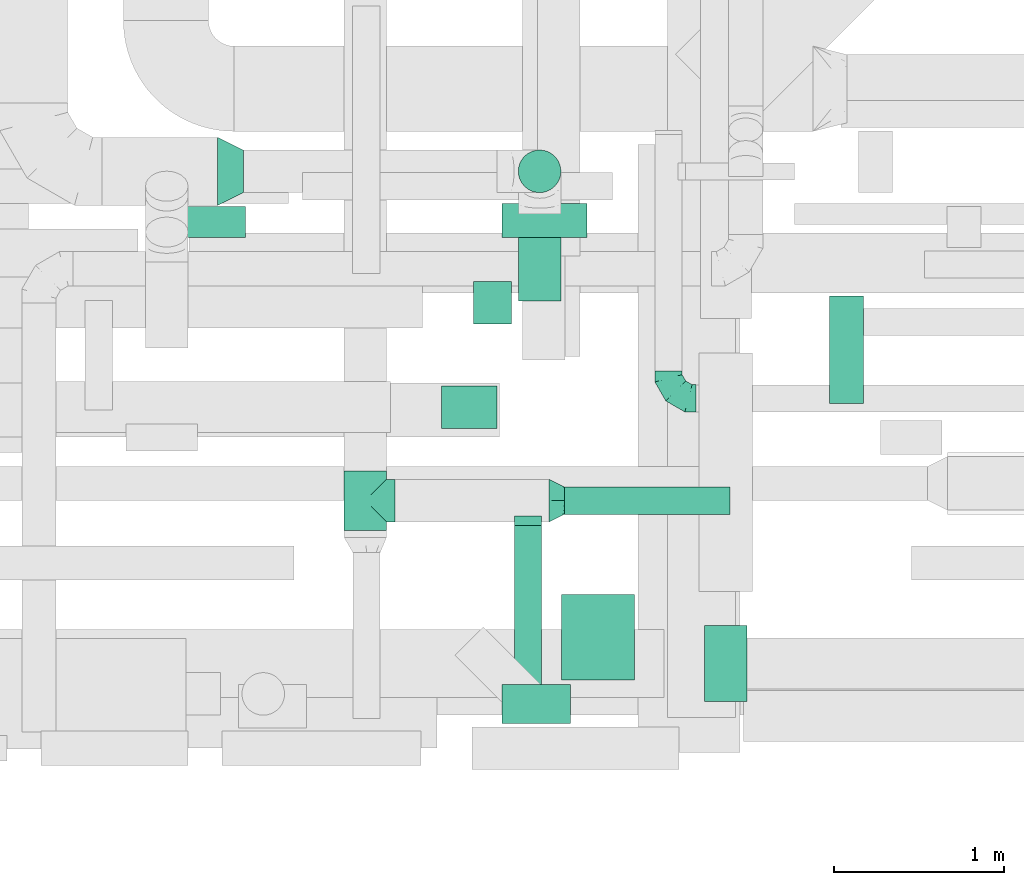
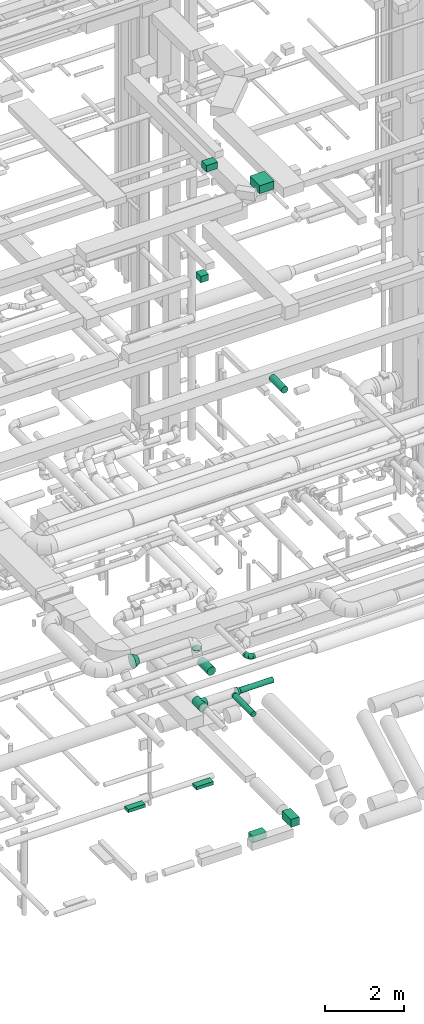
# One storey, part 162 of 337: 12 flow segments, 5 flow fittings.
"""IFC2X3 building model written with IfcOpenShell, lengths in millimetres."""

import ifcopenshell
import ifcopenshell.guid

model = None  # the IFC model being written
_history = None  # IfcOwnerHistory: only IFC2X3 demands one
_inside = {}  # id of a spatial element -> (the spatial element, [elements in it])
_under = {}  # id of a project, library or spatial element -> (it, [spatial elements below it])
_declared = {}  # id of a project -> (the project, [libraries it declares])
_typed = {}  # id of a type object -> (the type object, [elements of that type])
_made_of = {}  # id of a material, layer set ... -> (it, [elements and type objects made of it])


def new_model(schema):
    """Start an empty IFC model of exactly this schema.

    Asked for "IFC4X3", IfcOpenShell would pick the latest addendum, in which some entities
    have other attributes; the version numbers below select the first issue.
    IFC2X3 requires an IfcOwnerHistory on every rooted entity: one is made here for all.
    """
    global model, _history
    if schema == "IFC4X3":
        model = ifcopenshell.file(schema_version=(4, 3, 0, 0))
    else:
        model = ifcopenshell.file(schema=schema)
    _inside.clear()
    _under.clear()
    _declared.clear()
    _typed.clear()
    _made_of.clear()
    _history = None
    if model.schema == "IFC2X3":
        org = make("IfcOrganization", Name="unknown")
        user = make(
            "IfcPersonAndOrganization",
            ThePerson=make("IfcPerson", FamilyName="unknown"),
            TheOrganization=org,
        )
        app = make(
            "IfcApplication",
            ApplicationDeveloper=org,
            Version="unknown",
            ApplicationFullName="unknown",
            ApplicationIdentifier="unknown",
        )
        _history = make(
            "IfcOwnerHistory",
            OwningUser=user,
            OwningApplication=app,
            ChangeAction="ADDED",
            CreationDate=0,
        )
    return model


def make(cls, **values):
    """One entity of the class cls with the attributes given. An attribute that is None is left unset."""
    return model.create_entity(
        cls, **{name: value for name, value in values.items() if value is not None}
    )


def entity(cls, *values):
    """Any entity or typed value of the class cls, its attributes in the order of the schema. None: left unset."""
    e = model.create_entity(cls)
    for i, value in enumerate(values):
        if value is not None:
            e[i] = value
    return e


def rooted(cls, **values):
    """An entity with a GlobalId (a new one), such as an element, a storey or a relation."""
    return make(cls, GlobalId=ifcopenshell.guid.new(), OwnerHistory=_history, **values)


def si_unit(unit_type, name, prefix=None):
    """IfcSIUnit, for example si_unit("LENGTHUNIT", "METRE", prefix="MILLI")."""
    return make("IfcSIUnit", UnitType=unit_type, Prefix=prefix, Name=name)


def converted_unit(unit_type, name, factor, base, dimensions=None, offset=None):
    """IfcConversionBasedUnit, such as the inch: factor (a typed value) times the base unit."""
    return make(
        "IfcConversionBasedUnit"
        if offset is None
        else "IfcConversionBasedUnitWithOffset",
        ConversionOffset=offset,
        Dimensions=None
        if dimensions is None
        else entity("IfcDimensionalExponents", *dimensions),
        UnitType=unit_type,
        Name=name,
        ConversionFactor=make(
            "IfcMeasureWithUnit", ValueComponent=factor, UnitComponent=base
        ),
    )


def derived_unit(unit_type, elements):
    """IfcDerivedUnit: a product of units, each with its exponent."""
    return make(
        "IfcDerivedUnit",
        Elements=[
            make("IfcDerivedUnitElement", Unit=unit, Exponent=power)
            for unit, power in elements
        ],
        UnitType=unit_type,
    )


def assignment(units):
    """IfcUnitAssignment: the units of a project."""
    return None if units is None else make("IfcUnitAssignment", Units=units)


def point(xyz):
    """IfcCartesianPoint."""
    return None if xyz is None else make("IfcCartesianPoint", Coordinates=xyz)


def direction(xyz):
    """IfcDirection."""
    return None if xyz is None else make("IfcDirection", DirectionRatios=xyz)


def frame(location, z_axis=None, x_axis=None):
    """IfcAxis2Placement3D, a coordinate frame: its origin and axes. An axis left out is left unset."""
    return make(
        "IfcAxis2Placement3D",
        Location=point(location),
        Axis=direction(z_axis),
        RefDirection=direction(x_axis),
    )


def frame_2d(location, x_axis=None):
    """IfcAxis2Placement2D, a coordinate frame in the plane: its origin and x axis."""
    return make(
        "IfcAxis2Placement2D", Location=point(location), RefDirection=direction(x_axis)
    )


def origin():
    """The frame at (0, 0, 0) with its axes left unset."""
    return frame((0.0, 0.0, 0.0))


def origin_2d_with_axis():
    """The frame at (0, 0) in the plane with the x axis (1, 0) written out."""
    return frame_2d((0.0, 0.0), x_axis=(1.0, 0.0))


def place(relative_to, where):
    """IfcLocalPlacement: puts the frame where relative to a parent placement (None: the world)."""
    return make(
        "IfcLocalPlacement", PlacementRelTo=relative_to, RelativePlacement=where
    )


def context(
    kind, dimensions, precision=None, world=None, true_north=None, identifier=None
):
    """IfcGeometricRepresentationContext, for example the 3D "Model" context."""
    return make(
        "IfcGeometricRepresentationContext",
        ContextIdentifier=identifier,
        ContextType=kind,
        CoordinateSpaceDimension=dimensions,
        Precision=precision,
        WorldCoordinateSystem=world,
        TrueNorth=true_north,
    )


def subcontext(parent, identifier, kind, view, scale=None):
    """IfcGeometricRepresentationSubContext, for example "Body" below "Model"."""
    return make(
        "IfcGeometricRepresentationSubContext",
        ContextIdentifier=identifier,
        ContextType=kind,
        ParentContext=parent,
        TargetScale=scale,
        TargetView=view,
    )


def project(units=None, contexts=None):
    """IfcProject with its units and contexts."""
    return rooted(
        "IfcProject",
        Name="project",
        RepresentationContexts=contexts,
        UnitsInContext=assignment(units),
    )


def spatial(cls, under=None, at=None, **own):
    """A site, building, storey or space (cls), placed at a placement, below another one or the project."""
    s = rooted(cls, ObjectPlacement=at, **own)
    if under is not None:
        _under.setdefault(under.id(), (under, []))[1].append(s)
    return s


def profile(cls, at=None, kind="AREA", **sizes):
    """A parametric profile (cls). Its sizes go by their IFC names, for example OverallWidth=200.0."""
    return make(cls, ProfileType=kind, Position=at, **sizes)


def rectangle(**sizes):
    """IfcRectangleProfileDef."""
    return profile("IfcRectangleProfileDef", **sizes)


def circle(**sizes):
    """IfcCircleProfileDef."""
    return profile("IfcCircleProfileDef", **sizes)


def extrude(swept, where, along, depth):
    """IfcExtrudedAreaSolid: the profile swept, set in the frame where, extruded along a direction by depth."""
    return make(
        "IfcExtrudedAreaSolid",
        SweptArea=swept,
        Position=where,
        ExtrudedDirection=direction(along),
        Depth=depth,
    )


def faces_of(points, faces, orient=None, outer=None):
    """IfcFace entities. A face is a list of loops; a loop is a list of indices into points, from 0.

    orient and outer hold one flag for each loop. By default every Orientation is true, the
    first loop of a face is its IfcFaceOuterBound and the others are IfcFaceBound.
    """
    made = []
    for i, loops in enumerate(faces):
        bounds = []
        for j, loop in enumerate(loops):
            is_outer = j == 0 if outer is None else outer[i][j]
            bounds.append(
                make(
                    "IfcFaceOuterBound" if is_outer else "IfcFaceBound",
                    Bound=make("IfcPolyLoop", Polygon=[points[k] for k in loop]),
                    Orientation=True if orient is None else orient[i][j],
                )
            )
        made.append(make("IfcFace", Bounds=bounds))
    return made


def faceted_brep(points, faces, orient=None, outer=None, voids=None):
    """IfcFacetedBrep: a solid bounded by flat faces; with voids (closed shells), ...WithVoids."""
    shared = [point(p) for p in points]
    hull = make("IfcClosedShell", CfsFaces=faces_of(shared, faces, orient, outer))
    if voids is None:
        return make("IfcFacetedBrep", Outer=hull)
    return make(
        "IfcFacetedBrepWithVoids",
        Outer=hull,
        Voids=[
            make(cls, CfsFaces=faces_of(shared, fs, o, b)) for cls, fs, o, b in voids
        ],
    )


def shape(context_of_items, identifier, shape_type, items):
    """IfcShapeRepresentation: the items that make up one representation, for example the "Body"."""
    return make(
        "IfcShapeRepresentation",
        ContextOfItems=context_of_items,
        RepresentationIdentifier=identifier,
        RepresentationType=shape_type,
        Items=items,
    )


def source(mapping_origin, context_of_items, identifier, shape_type, items):
    """IfcRepresentationMap: a shape defined once, which mapped items show again and again."""
    return make(
        "IfcRepresentationMap",
        MappingOrigin=mapping_origin,
        MappedRepresentation=shape(context_of_items, identifier, shape_type, items),
    )


def transform(
    local_origin,
    x_axis=None,
    y_axis=None,
    z_axis=None,
    scale=None,
    scale2=None,
    scale3=None,
    uniform=True,
):
    """IfcCartesianTransformationOperator3D, or its non-uniform kind. x_axis, y_axis, z_axis: its Axis1, 2, 3."""
    if uniform:
        return make(
            "IfcCartesianTransformationOperator3D",
            Axis1=direction(x_axis),
            Axis2=direction(y_axis),
            LocalOrigin=point(local_origin),
            Scale=scale,
            Axis3=direction(z_axis),
        )
    return make(
        "IfcCartesianTransformationOperator3DnonUniform",
        Axis1=direction(x_axis),
        Axis2=direction(y_axis),
        LocalOrigin=point(local_origin),
        Scale=scale,
        Axis3=direction(z_axis),
        Scale2=scale2,
        Scale3=scale3,
    )


def mapped(mapping_source, mapping_target):
    """IfcMappedItem: shows the shape of a source again, moved by a transform."""
    return make(
        "IfcMappedItem", MappingSource=mapping_source, MappingTarget=mapping_target
    )


def material(Name=None, Category=None):
    """IfcMaterial."""
    return make("IfcMaterial", Name=Name, Category=Category)


def made_of(thing, what):
    """Note that an element or type object is made of a material, layer set ...; save() writes the relation."""
    if what is not None:
        _made_of.setdefault(what.id(), (what, []))[1].append(thing)
    return thing


def type_object(cls, material=None, **own):
    """A type object (cls), such as IfcWallType, which elements share."""
    return made_of(rooted(cls, **own), material)


def type_shapes(of_type, sources):
    """Give a type object the sources (RepresentationMaps) that its elements show as mapped items."""
    of_type.RepresentationMaps = sources


def element(
    cls,
    number,
    at=None,
    inside=None,
    cuts=None,
    type_object=None,
    material=None,
    context=None,
    identifier="Body",
    shape_type=None,
    held_by="IfcProductDefinitionShape",
    body=None,
    shapes=None,
    **own,
):
    """One element of the class cls, such as IfcWall. Its Tag is "e" and its number.

    at: its placement. inside: the storey or other place that contains it. cuts: it is an
    opening in that element (IfcRelVoidsElement). A single representation is given by context,
    identifier, shape_type and body (its items); several are given by shapes. held_by: the class
    of the entity that holds the representations. save() writes the other relations.
    """
    e = rooted(cls, Tag="e%d" % number, ObjectPlacement=at, **own)
    if body is not None:
        shapes = [shape(context, identifier, shape_type, body)]
    if shapes is not None:
        e.Representation = make(held_by, Representations=shapes)
    if inside is not None:
        _inside.setdefault(inside.id(), (inside, []))[1].append(e)
    if cuts is not None:
        rooted(
            "IfcRelVoidsElement", RelatingBuildingElement=cuts, RelatedOpeningElement=e
        )
    if type_object is not None:
        _typed.setdefault(type_object.id(), (type_object, []))[1].append(e)
    return made_of(e, material)


def aggregate(whole, parts):
    """IfcRelAggregates: a whole, such as a stair, and the parts it consists of."""
    return rooted("IfcRelAggregates", RelatingObject=whole, RelatedObjects=parts)


def save(model, path):
    """Write the relations noted so far, then the file.

    IfcRelAggregates (storeys below a building ...), IfcRelContainedInSpatialStructure (elements
    in a storey), IfcRelDefinesByType, IfcRelAssociatesMaterial and IfcRelDeclares: one each for
    every whole, place, type object, material and project.
    """
    for whole, parts in _under.values():
        aggregate(whole, parts)
    for where, things in _inside.values():
        rooted(
            "IfcRelContainedInSpatialStructure",
            RelatedElements=things,
            RelatingStructure=where,
        )
    for kind, things in _typed.values():
        rooted("IfcRelDefinesByType", RelatedObjects=things, RelatingType=kind)
    for what, things in _made_of.values():
        rooted("IfcRelAssociatesMaterial", RelatedObjects=things, RelatingMaterial=what)
    for by, libraries in _declared.values():
        rooted("IfcRelDeclares", RelatingContext=by, RelatedDefinitions=libraries)
    model.write(path)


model = new_model("IFC2X3")

# Units and contexts
model_context = context("Model", 3, precision=0.01, world=origin(), true_north=direction((6.12303176911189e-17, 1.0)))
body_context = subcontext(model_context, "Body", "Model", "MODEL_VIEW")
ifc_project = project(units=[si_unit("LENGTHUNIT", "METRE", prefix="MILLI"), si_unit("AREAUNIT", "SQUARE_METRE"), si_unit("VOLUMEUNIT", "CUBIC_METRE"), converted_unit("PLANEANGLEUNIT", "DEGREE", entity("IfcRatioMeasure", 0.0174532925199433), si_unit("PLANEANGLEUNIT", "RADIAN"), dimensions=[0, 0, 0, 0, 0, 0, 0]), si_unit("MASSUNIT", "GRAM", prefix="KILO"), derived_unit("MASSDENSITYUNIT", [(si_unit("MASSUNIT", "GRAM", prefix="KILO"), 1), (si_unit("LENGTHUNIT", "METRE"), -3)]), derived_unit("MOMENTOFINERTIAUNIT", [(si_unit("LENGTHUNIT", "METRE"), 4)]), si_unit("TIMEUNIT", "SECOND"), si_unit("FREQUENCYUNIT", "HERTZ"), si_unit("THERMODYNAMICTEMPERATUREUNIT", "DEGREE_CELSIUS"), derived_unit("THERMALTRANSMITTANCEUNIT", [(si_unit("MASSUNIT", "GRAM", prefix="KILO"), 1), (si_unit("THERMODYNAMICTEMPERATUREUNIT", "KELVIN"), -1), (si_unit("TIMEUNIT", "SECOND"), -3)]), derived_unit("VOLUMETRICFLOWRATEUNIT", [(si_unit("LENGTHUNIT", "METRE"), 3), (si_unit("TIMEUNIT", "SECOND"), -1)]), derived_unit("MASSFLOWRATEUNIT", [(si_unit("MASSUNIT", "GRAM", prefix="KILO"), 1), (si_unit("TIMEUNIT", "SECOND"), -1)]), derived_unit("ROTATIONALFREQUENCYUNIT", [(si_unit("TIMEUNIT", "SECOND"), -1)]), si_unit("ELECTRICCURRENTUNIT", "AMPERE"), si_unit("ELECTRICVOLTAGEUNIT", "VOLT"), si_unit("POWERUNIT", "WATT"), si_unit("FORCEUNIT", "NEWTON", prefix="KILO"), si_unit("ILLUMINANCEUNIT", "LUX"), si_unit("LUMINOUSFLUXUNIT", "LUMEN"), si_unit("LUMINOUSINTENSITYUNIT", "CANDELA"), derived_unit("USERDEFINED", [(si_unit("MASSUNIT", "GRAM", prefix="KILO"), -1), (si_unit("LENGTHUNIT", "METRE"), -2), (si_unit("TIMEUNIT", "SECOND"), 3), (si_unit("LUMINOUSFLUXUNIT", "LUMEN"), 1)]), derived_unit("LINEARVELOCITYUNIT", [(si_unit("LENGTHUNIT", "METRE"), 1), (si_unit("TIMEUNIT", "SECOND"), -1)]), si_unit("PRESSUREUNIT", "PASCAL"), derived_unit("USERDEFINED", [(si_unit("LENGTHUNIT", "METRE"), -2), (si_unit("MASSUNIT", "GRAM", prefix="KILO"), 1), (si_unit("TIMEUNIT", "SECOND"), -2)]), derived_unit("LINEARFORCEUNIT", [(si_unit("MASSUNIT", "GRAM", prefix="KILO"), 1), (si_unit("LENGTHUNIT", "METRE"), 1), (si_unit("TIMEUNIT", "SECOND"), -2), (si_unit("LENGTHUNIT", "METRE"), -1)]), derived_unit("PLANARFORCEUNIT", [(si_unit("MASSUNIT", "GRAM", prefix="KILO"), 1), (si_unit("LENGTHUNIT", "METRE"), 1), (si_unit("TIMEUNIT", "SECOND"), -2), (si_unit("LENGTHUNIT", "METRE"), -2)])], contexts=[model_context])

# Site, building, storey
site_placement = place(None, origin())
site = spatial("IfcSite", under=ifc_project, at=site_placement, CompositionType="ELEMENT")
building_placement = place(site_placement, origin())
building = spatial("IfcBuilding", under=site, at=building_placement, CompositionType="ELEMENT")
storey_placement = place(building_placement, origin())
storey = spatial("IfcBuildingStorey", under=building, at=storey_placement, CompositionType="ELEMENT", Elevation=0.0)

# Flow segments
duct_segment_type_1 = type_object("IfcDuctSegmentType", PredefinedType="NOTDEFINED")
flow_segment_1_placement = place(storey_placement, frame((48148.45, 3273.53, -900.0)))
element("IfcFlowSegment", 1, at=flow_segment_1_placement, inside=storey, type_object=duct_segment_type_1, context=body_context, shape_type="SweptSolid", body=[
    extrude(rectangle(XDim=199.999971499982, YDim=499.999999999999, at=origin_2d_with_axis()), frame((250.0, 100.0, 0.0), z_axis=(0.0, 0.0, 1.0), x_axis=(0.0, -1.0, 0.0)), (0.0, 0.0, 1.0), 100.0),
])
flow_segment_2_placement = place(storey_placement, frame((46144.41, 3273.53, -900.0)))
element("IfcFlowSegment", 2, at=flow_segment_2_placement, inside=storey, type_object=duct_segment_type_1, context=body_context, shape_type="SweptSolid", body=[
    extrude(rectangle(XDim=179.999983999988, YDim=499.999999999999, at=origin_2d_with_axis()), frame((250.0, 90.0, 0.0), z_axis=(0.0, 0.0, 1.0), x_axis=(0.0, -1.0, 0.0)), (0.0, 0.0, 1.0), 100.0),
])
flow_segment_3_placement = place(storey_placement, frame((49338.6, 548.87, -825.0)))
element("IfcFlowSegment", 3, at=flow_segment_3_placement, inside=storey, type_object=duct_segment_type_1, context=body_context, shape_type="SweptSolid", body=[
    extrude(rectangle(XDim=446.507916250005, YDim=250.000000000004, at=origin_2d_with_axis()), frame((125.0, 223.25, 0.0), z_axis=(0.0, 0.0, 1.0), x_axis=(0.0, -1.0, 0.0)), (0.0, 0.0, 1.0), 250.0),
])
flow_segment_4_placement = place(storey_placement, frame((48150.01, 418.87, -800.0)))
element("IfcFlowSegment", 4, at=flow_segment_4_placement, inside=storey, type_object=duct_segment_type_1, context=body_context, shape_type="SweptSolid", body=[
    extrude(rectangle(XDim=229.999999999978, YDim=400.000000000004, at=origin_2d_with_axis()), frame((200.0, 115.0, 0.0), z_axis=(0.0, 0.0, 1.0), x_axis=(0.0, 1.0, 0.0)), (0.0, 0.0, 1.0), 200.0),
])
flow_segment_5_placement = place(storey_placement, frame((47795.22, 2152.06, 19075.0)))
element("IfcFlowSegment", 5, at=flow_segment_5_placement, inside=storey, type_object=duct_segment_type_1, context=body_context, shape_type="SweptSolid", body=[
    extrude(rectangle(XDim=324.999999999961, YDim=250.0, at=origin_2d_with_axis()), frame((162.5, 125.0, 0.0)), (0.0, 0.0, 1.0), 200.000000000002),
])
flow_segment_6_placement = place(storey_placement, frame((47981.01, 2765.44, 15200.0)))
element("IfcFlowSegment", 6, at=flow_segment_6_placement, inside=storey, type_object=duct_segment_type_1, context=body_context, shape_type="SweptSolid", body=[
    extrude(rectangle(XDim=225.00000000007, YDim=250.0, at=origin_2d_with_axis()), frame((112.5, 125.0, 0.0)), (0.0, 0.0, 1.0), 199.999999999998),
])
flow_segment_7_placement = place(storey_placement, frame((48498.92, 675.82, 19050.0)))
element("IfcFlowSegment", 7, at=flow_segment_7_placement, inside=storey, type_object=duct_segment_type_1, context=body_context, shape_type="SweptSolid", body=[
    extrude(rectangle(XDim=428.314575050776, YDim=500.0, at=origin_2d_with_axis()), frame((214.16, 250.0, 0.0), z_axis=(0.0, 0.0, 1.0), x_axis=(-1.0, 0.0, 0.0)), (0.0, 0.0, 1.0), 249.999999999999),
])
duct_segment_type_2 = type_object("IfcDuctSegmentType", PredefinedType="NOTDEFINED")
flow_segment_8_placement = place(storey_placement, frame((50069.44, 2299.16, 11298.4)))
element("IfcFlowSegment", 8, at=flow_segment_8_placement, inside=storey, type_object=duct_segment_type_2, context=body_context, shape_type="SweptSolid", body=[
    extrude(circle(Radius=100.0, at=origin_2d_with_axis()), frame((101.6, 0.0, 101.6), z_axis=(0.0, 1.0, 0.0), x_axis=(-1.0, 0.0, 0.0)), (0.0, 0.0, 1.0), 628.712130818975),
])
flow_segment_9_placement = place(storey_placement, frame((48516.39, 1646.2, 2918.4)))
element("IfcFlowSegment", 9, at=flow_segment_9_placement, inside=storey, type_object=duct_segment_type_2, context=body_context, shape_type="SweptSolid", body=[
    extrude(circle(Radius=80.0, at=origin_2d_with_axis()), frame((0.0, 81.6, 81.6), z_axis=(1.0, 0.0, 0.0), x_axis=(0.0, -1.0, 0.0)), (0.0, 0.0, 1.0), 969.999999999996),
])
flow_segment_10_placement = place(storey_placement, frame((48243.25, 3534.65, 3190.0)))
element("IfcFlowSegment", 10, at=flow_segment_10_placement, inside=storey, type_object=duct_segment_type_2, context=body_context, shape_type="SweptSolid", body=[
    extrude(circle(Radius=125.0, at=origin_2d_with_axis()), frame((126.6, 126.6, 0.0), z_axis=(0.0, 0.0, 1.0), x_axis=(0.0, 1.0, 0.0)), (0.0, 0.0, 1.0), 10.0000000000129),
])
flow_segment_11_placement = place(storey_placement, frame((48243.25, 2901.24, 2813.4)))
element("IfcFlowSegment", 11, at=flow_segment_11_placement, inside=storey, type_object=duct_segment_type_2, context=body_context, shape_type="SweptSolid", body=[
    extrude(circle(Radius=125.0, at=origin_2d_with_axis()), frame((126.6, 0.0, 126.6), z_axis=(0.0, 1.0, 0.0), x_axis=(-1.0, 0.0, 0.0)), (0.0, 0.0, 1.0), 509.999999999984),
])
flow_segment_12_placement = place(storey_placement, frame((48219.8, 642.79, 2918.4)))
element("IfcFlowSegment", 12, at=flow_segment_12_placement, inside=storey, type_object=duct_segment_type_2, context=body_context, shape_type="SweptSolid", body=[
    extrude(circle(Radius=80.0, at=origin_2d_with_axis()), frame((81.6, 0.0, 81.6), z_axis=(0.0, 1.0, 0.0), x_axis=(-1.0, 0.0, 0.0)), (0.0, 0.0, 1.0), 939.999999999988),
])

# Flow fittings
ifc_material = material()
duct_fitting_type_1 = type_object("IfcDuctFittingType", PredefinedType="NOTDEFINED", material=ifc_material)
shared_shape_1 = source(origin(), body_context, "Body", "Brep", [
    faceted_brep([(-160.0, 0.0, -80.0), (-160.0, -20.71, -77.27), (-160.0, -40.0, -69.28), (-160.0, -56.57, -56.57), (-160.0, -69.28, -40.0), (-160.0, -77.27, -20.71), (-160.0, -80.0, 0.0), (-160.0, -77.27, 20.71), (-160.0, -69.28, 40.0), (-160.0, -56.57, 56.57), (-160.0, -40.0, 69.28), (-160.0, -20.71, 77.27), (-160.0, 0.0, 80.0), (-160.0, 20.71, 77.27), (-160.0, 40.0, 69.28), (-160.0, 56.57, 56.57), (-160.0, 69.28, 40.0), (-160.0, 77.27, 20.71), (-160.0, 80.0, 0.0), (-160.0, 77.27, -20.71), (-160.0, 69.28, -40.0), (-160.0, 56.57, -56.57), (-160.0, 40.0, -69.28), (-160.0, 20.71, -77.27), (-122.68, 20.71, 77.27), (-127.85, 40.0, 69.28), (-117.13, 0.0, 80.0), (-132.29, 56.57, 56.57), (-137.83, 77.27, 20.71), (-138.56, 80.0, 0.0), (-135.69, 69.28, 40.0), (-135.69, 69.28, -40.0), (-132.29, 56.57, -56.57), (-137.83, 77.27, -20.71), (-122.68, 20.71, -77.27), (-117.13, 0.0, -80.0), (-127.85, 40.0, -69.28), (-111.58, -20.71, -77.27), (-106.41, -40.0, -69.28), (-101.97, -56.57, -56.57), (-98.56, -69.28, -40.0), (-96.42, -77.27, -20.71), (-95.69, -80.0, 0.0), (-96.42, -77.27, 20.71), (-98.56, -69.28, 40.0), (-101.97, -56.57, 56.57), (-106.41, -40.0, 69.28), (-111.58, -20.71, 77.27), (-58.03, 58.03, 77.27), (-72.15, 72.15, 69.28), (-42.87, 42.87, 80.0), (-84.28, 84.28, 56.57), (-93.59, 93.59, 40.0), (-99.44, 99.44, 20.71), (-101.44, 101.44, 0.0), (-99.44, 99.44, -20.71), (-93.59, 93.59, -40.0), (-84.28, 84.28, -56.57), (-58.03, 58.03, -77.27), (-42.87, 42.87, -80.0), (-72.15, 72.15, -69.28), (-27.71, 27.71, -77.27), (-13.59, 13.59, -69.28), (-1.46, 1.46, -56.57), (7.85, -7.85, -40.0), (13.7, -13.7, -20.71), (15.69, -15.69, 0.0), (13.7, -13.7, 20.71), (7.85, -7.85, 40.0), (-1.46, 1.46, 56.57), (-13.59, 13.59, 69.28), (-27.71, 27.71, 77.27), (-20.71, 122.68, 77.27), (-40.0, 127.85, 69.28), (0.0, 117.13, 80.0), (-56.57, 132.29, 56.57), (-69.28, 135.69, 40.0), (-77.27, 137.83, 20.71), (-80.0, 138.56, 0.0), (-77.27, 137.83, -20.71), (-69.28, 135.69, -40.0), (-56.57, 132.29, -56.57), (-20.71, 122.68, -77.27), (0.0, 117.13, -80.0), (-40.0, 127.85, -69.28), (20.71, 111.58, -77.27), (40.0, 106.41, -69.28), (56.57, 101.97, -56.57), (69.28, 98.56, -40.0), (77.27, 96.42, -20.71), (80.0, 95.69, 0.0), (77.27, 96.42, 20.71), (69.28, 98.56, 40.0), (56.57, 101.97, 56.57), (40.0, 106.41, 69.28), (20.71, 111.58, 77.27), (-20.71, 160.0, -77.27), (-40.0, 160.0, -69.28), (-56.57, 160.0, -56.57), (-69.28, 160.0, -40.0), (-77.27, 160.0, -20.71), (-80.0, 160.0, 0.0), (-77.27, 160.0, 20.71), (-69.28, 160.0, 40.0), (-56.57, 160.0, 56.57), (-40.0, 160.0, 69.28), (-20.71, 160.0, 77.27), (0.0, 160.0, 80.0), (20.71, 160.0, 77.27), (40.0, 160.0, 69.28), (56.57, 160.0, 56.57), (69.28, 160.0, 40.0), (77.27, 160.0, 20.71), (80.0, 160.0, 0.0), (77.27, 160.0, -20.71), (69.28, 160.0, -40.0), (56.57, 160.0, -56.57), (40.0, 160.0, -69.28), (20.71, 160.0, -77.27), (0.0, 160.0, -80.0)], [[[0, 1, 2, 3, 4, 5, 6, 7, 8, 9, 10, 11, 12, 13, 14, 15, 16, 17, 18, 19, 20, 21, 22, 23]], [[24, 25, 14, 13]], [[26, 24, 13, 12]], [[14, 25, 27, 15]], [[28, 29, 18, 17]], [[30, 28, 17, 16]], [[15, 27, 30, 16]], [[20, 31, 32, 21]], [[33, 31, 20, 19]], [[18, 29, 33, 19]], [[34, 35, 0, 23]], [[36, 34, 23, 22]], [[32, 36, 22, 21]], [[1, 0, 35, 37]], [[2, 1, 37, 38]], [[3, 2, 38, 39]], [[5, 4, 40, 41]], [[6, 5, 41, 42]], [[39, 40, 4, 3]], [[6, 42, 43, 7]], [[7, 43, 44, 8]], [[8, 44, 45, 9]], [[9, 45, 46, 10]], [[10, 46, 47, 11]], [[26, 12, 11, 47]], [[48, 49, 25, 24]], [[50, 48, 24, 26]], [[27, 25, 49, 51]], [[52, 53, 28, 30]], [[51, 52, 30, 27]], [[29, 28, 53, 54]], [[55, 56, 31, 33]], [[54, 55, 33, 29]], [[32, 31, 56, 57]], [[58, 59, 35, 34]], [[60, 58, 34, 36]], [[57, 60, 36, 32]], [[37, 35, 59, 61]], [[38, 37, 61, 62]], [[39, 38, 62, 63]], [[41, 40, 64, 65]], [[42, 41, 65, 66]], [[63, 64, 40, 39]], [[43, 42, 66, 67]], [[44, 43, 67, 68]], [[68, 69, 45, 44]], [[46, 45, 69, 70]], [[47, 46, 70, 71]], [[26, 47, 71, 50]], [[72, 73, 49, 48]], [[74, 72, 48, 50]], [[51, 49, 73, 75]], [[76, 77, 53, 52]], [[75, 76, 52, 51]], [[54, 53, 77, 78]], [[79, 80, 56, 55]], [[78, 79, 55, 54]], [[57, 56, 80, 81]], [[82, 83, 59, 58]], [[84, 82, 58, 60]], [[81, 84, 60, 57]], [[61, 59, 83, 85]], [[62, 61, 85, 86]], [[63, 62, 86, 87]], [[65, 64, 88, 89]], [[66, 65, 89, 90]], [[87, 88, 64, 63]], [[67, 66, 90, 91]], [[68, 67, 91, 92]], [[92, 93, 69, 68]], [[70, 69, 93, 94]], [[71, 70, 94, 95]], [[50, 71, 95, 74]], [[96, 97, 98, 99, 100, 101, 102, 103, 104, 105, 106, 107, 108, 109, 110, 111, 112, 113, 114, 115, 116, 117, 118, 119]], [[72, 74, 107, 106]], [[73, 72, 106, 105]], [[75, 73, 105, 104]], [[77, 76, 103, 102]], [[78, 77, 102, 101]], [[75, 104, 103, 76]], [[78, 101, 100, 79]], [[79, 100, 99, 80]], [[80, 99, 98, 81]], [[84, 97, 96, 82]], [[82, 96, 119, 83]], [[84, 81, 98, 97]], [[118, 117, 86, 85]], [[119, 118, 85, 83]], [[116, 87, 86, 117]], [[88, 115, 114, 89]], [[89, 114, 113, 90]], [[115, 88, 87, 116]], [[112, 111, 92, 91]], [[113, 112, 91, 90]], [[111, 110, 93, 92]], [[95, 94, 109, 108]], [[74, 95, 108, 107]], [[110, 109, 94, 93]]]),
])
type_shapes(duct_fitting_type_1, [shared_shape_1])
flow_fitting_1_placement = place(storey_placement, frame((49126.6, 2328.65, 3450.0), z_axis=(0.0, 0.0, 1.0), x_axis=(0.0, -1.0, 0.0)))
element("IfcFlowFitting", 13, at=flow_fitting_1_placement, inside=storey, type_object=duct_fitting_type_1, material=ifc_material, context=body_context, shape_type="MappedRepresentation", body=[
    mapped(shared_shape_1, transform((0.0, 0.0, 0.0), scale=1.0)),
])
duct_fitting_type_2 = type_object("IfcDuctFittingType", PredefinedType="NOTDEFINED", material=ifc_material)
shared_shape_2 = source(origin(), body_context, "Body", "Brep", [
    faceted_brep([(90.0, -73.91, 30.61), (90.0, -76.96, 15.31), (90.0, -80.0, 0.0), (90.0, -76.96, -15.31), (90.0, -73.91, -30.61), (90.0, -65.24, -43.59), (90.0, -56.57, -56.57), (90.0, -43.59, -65.24), (90.0, -30.61, -73.91), (90.0, -15.31, -76.96), (90.0, 0.0, -80.0), (90.0, 15.31, -76.96), (90.0, 30.61, -73.91), (90.0, 43.59, -65.24), (90.0, 56.57, -56.57), (90.0, 65.24, -43.59), (90.0, 73.91, -30.61), (90.0, 76.96, -15.31), (90.0, 80.0, 0.0), (90.0, 76.96, 15.31), (90.0, 73.91, 30.61), (90.0, 65.24, 43.59), (90.0, 56.57, 56.57), (90.0, 43.59, 65.24), (90.0, 30.61, 73.91), (90.0, 15.31, 76.96), (90.0, 0.0, 80.0), (90.0, -15.31, 76.96), (90.0, -30.61, 73.91), (90.0, -43.59, 65.24), (90.0, -56.57, 56.57), (90.0, -65.24, 43.59), (0.0, -125.0, 0.0), (0.0, -118.88, 38.63), (0.0, -101.13, 73.47), (0.0, -73.47, 101.13), (0.0, -38.63, 118.88), (0.0, 0.0, 125.0), (0.0, 38.63, 118.88), (0.0, 73.47, 101.13), (0.0, 101.13, 73.47), (0.0, 118.88, 38.63), (0.0, 125.0, 0.0), (0.0, 118.88, -38.63), (0.0, 101.13, -73.47), (0.0, 73.47, -101.13), (0.0, 38.63, -118.88), (0.0, 0.0, -125.0), (0.0, -38.63, -118.88), (0.0, -73.47, -101.13), (0.0, -101.13, -73.47), (0.0, -118.88, -38.63)], [[[0, 1, 2, 3, 4, 5, 6, 7, 8, 9, 10, 11, 12, 13, 14, 15, 16, 17, 18, 19, 20, 21, 22, 23, 24, 25, 26, 27, 28, 29, 30, 31]], [[32, 33, 34, 35, 36, 37, 38, 39, 40, 41, 42, 43, 44, 45, 46, 47, 48, 49, 50, 51]], [[37, 25, 38]], [[24, 39, 38]], [[40, 22, 21, 20]], [[23, 22, 39, 24]], [[41, 20, 19]], [[18, 42, 19]], [[25, 24, 38]], [[40, 20, 41]], [[19, 42, 41]], [[25, 37, 26]], [[22, 40, 39]], [[32, 1, 33]], [[0, 34, 33]], [[35, 30, 29, 28]], [[31, 30, 34, 0]], [[36, 28, 27]], [[26, 37, 27]], [[1, 0, 33]], [[35, 28, 36]], [[27, 37, 36]], [[1, 32, 2]], [[30, 35, 34]], [[47, 9, 48]], [[8, 49, 48]], [[50, 6, 5, 4]], [[7, 6, 49, 8]], [[51, 4, 3]], [[2, 32, 3]], [[9, 8, 48]], [[50, 4, 51]], [[3, 32, 51]], [[9, 47, 10]], [[6, 50, 49]], [[42, 17, 43]], [[16, 44, 43]], [[45, 14, 13, 12]], [[15, 14, 44, 16]], [[46, 12, 11]], [[10, 47, 11]], [[17, 16, 43]], [[45, 12, 46]], [[11, 47, 46]], [[17, 42, 18]], [[14, 45, 44]]]),
])
type_shapes(duct_fitting_type_2, [shared_shape_2])
flow_fitting_2_placement = place(storey_placement, frame((48426.39, 1727.79, 3000.0)))
element("IfcFlowFitting", 14, at=flow_fitting_2_placement, inside=storey, type_object=duct_fitting_type_2, material=ifc_material, context=body_context, shape_type="MappedRepresentation", body=[
    mapped(shared_shape_2, transform((0.0, 0.0, 0.0), scale=1.0)),
])
duct_fitting_type_3 = type_object("IfcDuctFittingType", PredefinedType="NOTDEFINED", material=ifc_material)
shared_shape_3 = source(origin(), body_context, "Body", "Brep", [
    faceted_brep([(20.0, 20.71, -77.27), (20.0, 40.0, -69.28), (20.0, 56.57, -56.57), (20.0, 69.28, -40.0), (20.0, 77.27, -20.71), (20.0, 80.0, 0.0), (20.0, 77.27, 20.71), (20.0, 69.28, 40.0), (20.0, 56.57, 56.57), (20.0, 40.0, 69.28), (20.0, 20.71, 77.27), (20.0, 0.0, 80.0), (20.0, -20.71, 77.27), (20.0, -40.0, 69.28), (20.0, -56.57, 56.57), (20.0, -69.28, 40.0), (20.0, -77.27, 20.71), (20.0, -80.0, 0.0), (20.0, -77.27, -20.71), (20.0, -69.28, -40.0), (20.0, -56.57, -56.57), (20.0, -40.0, -69.28), (20.0, -20.71, -77.27), (20.0, 0.0, -80.0), (0.0, 0.0, 80.0), (0.0, 20.71, 77.27), (-35.05, 20.71, 77.27), (-35.05, 0.0, 80.0), (0.0, 40.0, 69.28), (-35.05, 40.0, 69.28), (0.0, 56.57, 56.57), (-35.05, 56.57, 56.57), (0.0, 69.28, 40.0), (0.0, 77.27, 20.71), (-35.05, 77.27, 20.71), (-35.05, 69.28, 40.0), (0.0, 80.0, 0.0), (-35.05, 80.0, 0.0), (0.0, 77.27, -20.71), (-35.05, 77.27, -20.71), (0.0, 69.28, -40.0), (-35.05, 69.28, -40.0), (0.0, 56.57, -56.57), (-35.05, 56.57, -56.57), (0.0, 40.0, -69.28), (0.0, 20.71, -77.27), (-35.05, 20.71, -77.27), (-35.05, 40.0, -69.28), (0.0, 0.0, -80.0), (-35.05, 0.0, -80.0), (0.0, -20.71, -77.27), (-35.05, -20.71, -77.27), (0.0, -40.0, -69.28), (-35.05, -40.0, -69.28), (0.0, -56.57, -56.57), (-35.05, -56.57, -56.57), (0.0, -69.28, -40.0), (0.0, -77.27, -20.71), (-35.05, -77.27, -20.71), (-35.05, -69.28, -40.0), (0.0, -80.0, 0.0), (-35.05, -80.0, 0.0), (0.0, -77.27, 20.71), (-35.05, -77.27, 20.71), (0.0, -69.28, 40.0), (-35.05, -69.28, 40.0), (0.0, -56.57, 56.57), (-35.05, -56.57, 56.57), (0.0, -40.0, 69.28), (0.0, -20.71, 77.27), (-35.05, -20.71, 77.27), (-35.05, -40.0, 69.28)], [[[0, 1, 2, 3, 4, 5, 6, 7, 8, 9, 10, 11, 12, 13, 14, 15, 16, 17, 18, 19, 20, 21, 22, 23]], [[24, 11, 10, 25, 26, 27]], [[25, 10, 9, 28, 29, 26]], [[28, 9, 8, 30, 31, 29]], [[32, 7, 6, 33, 34, 35]], [[33, 6, 5, 36, 37, 34]], [[30, 8, 7, 32, 35, 31]], [[36, 5, 4, 38, 39, 37]], [[38, 4, 3, 40, 41, 39]], [[40, 3, 2, 42, 43, 41]], [[44, 1, 0, 45, 46, 47]], [[45, 0, 23, 48, 49, 46]], [[42, 2, 1, 44, 47, 43]], [[48, 23, 22, 50, 51, 49]], [[50, 22, 21, 52, 53, 51]], [[52, 21, 20, 54, 55, 53]], [[56, 19, 18, 57, 58, 59]], [[57, 18, 17, 60, 61, 58]], [[54, 20, 19, 56, 59, 55]], [[60, 17, 16, 62, 63, 61]], [[62, 16, 15, 64, 65, 63]], [[64, 15, 14, 66, 67, 65]], [[68, 13, 12, 69, 70, 71]], [[69, 12, 11, 24, 27, 70]], [[66, 14, 13, 68, 71, 67]], [[49, 51, 53, 55, 59, 58, 61, 63, 65, 67, 71, 70, 27, 26, 29, 31, 35, 34, 37, 39, 41, 43, 47, 46]]]),
])
type_shapes(duct_fitting_type_3, [shared_shape_3])
flow_fitting_3_placement = place(storey_placement, frame((48301.39, 1602.79, 3000.0), z_axis=(0.0, 0.0, -1.0), x_axis=(0.0, -1.0, 0.0)))
element("IfcFlowFitting", 15, at=flow_fitting_3_placement, inside=storey, type_object=duct_fitting_type_3, material=ifc_material, context=body_context, shape_type="MappedRepresentation", body=[
    mapped(shared_shape_3, transform((0.0, 0.0, 0.0), scale=1.0)),
])
duct_fitting_type_4 = type_object("IfcDuctFittingType", PredefinedType="NOTDEFINED", material=ifc_material)
shared_shape_4 = source(origin(), body_context, "Body", "Brep", [
    faceted_brep([(22.44, -22.44, -122.97), (175.0, 0.0, -125.0), (175.0, -32.35, -120.74), (175.0, -62.5, -108.25), (75.83, -75.83, -99.37), (65.72, -65.72, -106.33), (175.0, -88.39, -88.39), (55.24, -55.24, -112.13), (11.24, -11.24, -124.49), (0.0, 0.0, -125.0), (-11.24, -11.24, -124.49), (-175.0, 0.0, -125.0), (44.49, -44.49, -116.81), (33.54, -33.54, -120.42), (175.0, -108.25, -62.5), (102.86, -102.86, -71.03), (175.0, -120.74, -32.35), (116.36, -116.36, -45.66), (175.0, -114.5, -47.43), (123.99, -123.99, -15.84), (175.0, -125.0, 0.0), (125.0, -125.0, 0.0), (-123.99, -123.99, -15.84), (-125.0, -125.0, 0.0), (-175.0, -125.0, 0.0), (175.0, -122.87, -16.18), (110.21, -110.21, -58.98), (121.05, -121.05, -31.19), (94.55, -94.55, -81.76), (85.49, -85.49, -91.2), (123.99, -123.99, 15.84), (-123.99, -123.99, 15.84), (175.0, -114.5, 47.43), (175.0, -108.25, 62.5), (110.21, -110.21, 58.98), (175.0, -120.74, 32.35), (121.05, -121.05, 31.19), (175.0, -122.87, 16.18), (102.86, -102.86, 71.03), (175.0, -88.39, 88.39), (116.36, -116.36, 45.66), (94.55, -94.55, 81.76), (85.49, -85.49, 91.2), (75.83, -75.83, 99.37), (65.72, -65.72, 106.33), (175.0, -62.5, 108.25), (55.24, -55.24, 112.13), (175.0, -32.35, 120.74), (22.44, -22.44, 122.97), (175.0, 0.0, 125.0), (44.49, -44.49, 116.81), (33.54, -33.54, 120.42), (11.24, -11.24, 124.49), (0.0, 0.0, 125.0), (-11.24, -11.24, 124.49), (-175.0, 0.0, 125.0), (32.35, -175.0, -120.74), (62.5, -175.0, -108.25), (88.39, -175.0, -88.39), (108.25, -175.0, -62.5), (114.5, -175.0, -47.43), (120.74, -175.0, -32.35), (122.87, -175.0, -16.18), (125.0, -175.0, 0.0), (122.87, -175.0, 16.18), (120.74, -175.0, 32.35), (114.5, -175.0, 47.43), (108.25, -175.0, 62.5), (88.39, -175.0, 88.39), (62.5, -175.0, 108.25), (32.35, -175.0, 120.74), (0.0, -175.0, 125.0), (-32.35, -175.0, 120.74), (-62.5, -175.0, 108.25), (-88.39, -175.0, 88.39), (-108.25, -175.0, 62.5), (-114.5, -175.0, 47.43), (-120.74, -175.0, 32.35), (-122.87, -175.0, 16.18), (-125.0, -175.0, 0.0), (-122.87, -175.0, -16.18), (-120.74, -175.0, -32.35), (-114.5, -175.0, -47.43), (-108.25, -175.0, -62.5), (-88.39, -175.0, -88.39), (-62.5, -175.0, -108.25), (-32.35, -175.0, -120.74), (0.0, -175.0, -125.0), (-22.44, -22.44, -122.97), (-75.83, -75.83, -99.37), (-65.72, -65.72, -106.33), (-55.24, -55.24, -112.13), (-44.49, -44.49, -116.81), (-33.54, -33.54, -120.42), (-102.86, -102.86, -71.03), (-116.36, -116.36, -45.66), (-110.21, -110.21, -58.98), (-121.05, -121.05, -31.19), (-94.55, -94.55, -81.76), (-85.49, -85.49, -91.2), (-110.21, -110.21, 58.98), (-121.05, -121.05, 31.19), (-102.86, -102.86, 71.03), (-116.36, -116.36, 45.66), (-94.55, -94.55, 81.76), (-85.49, -85.49, 91.2), (-75.83, -75.83, 99.37), (-65.72, -65.72, 106.33), (-55.24, -55.24, 112.13), (-22.44, -22.44, 122.97), (-44.49, -44.49, 116.81), (-33.54, -33.54, 120.42), (-175.0, -32.35, -120.74), (-175.0, -62.5, -108.25), (-175.0, -88.39, -88.39), (-175.0, -108.25, -62.5), (-175.0, -114.5, -47.43), (-175.0, -120.74, -32.35), (-175.0, -122.87, -16.18), (-175.0, -122.87, 16.18), (-175.0, -120.74, 32.35), (-175.0, -114.5, 47.43), (-175.0, -108.25, 62.5), (-175.0, -88.39, 88.39), (-175.0, -62.5, 108.25), (-175.0, -32.35, 120.74), (-175.0, 32.35, 120.74), (-175.0, 62.5, 108.25), (-175.0, 88.39, 88.39), (-175.0, 108.25, 62.5), (-175.0, 120.74, 32.35), (-175.0, 125.0, 0.0), (-175.0, 120.74, -32.35), (-175.0, 108.25, -62.5), (-175.0, 88.39, -88.39), (-175.0, 62.5, -108.25), (-175.0, 32.35, -120.74), (175.0, 32.35, -120.74), (175.0, 62.5, -108.25), (175.0, 88.39, -88.39), (175.0, 108.25, -62.5), (175.0, 120.74, -32.35), (175.0, 125.0, 0.0), (175.0, 120.74, 32.35), (175.0, 108.25, 62.5), (175.0, 88.39, 88.39), (175.0, 62.5, 108.25), (175.0, 32.35, 120.74)], [[[0, 1, 2]], [[3, 4, 5]], [[4, 3, 6]], [[2, 3, 7]], [[5, 7, 3]], [[8, 9, 1]], [[9, 10, 11]], [[0, 8, 1]], [[12, 13, 2]], [[7, 12, 2]], [[0, 2, 13]], [[14, 15, 6]], [[16, 17, 18]], [[19, 20, 21]], [[22, 23, 24]], [[20, 19, 25]], [[26, 18, 17]], [[27, 16, 25]], [[28, 29, 6]], [[15, 28, 6]], [[27, 25, 19]], [[26, 14, 18]], [[27, 17, 16]], [[15, 14, 26]], [[6, 29, 4]], [[30, 21, 20]], [[23, 31, 24]], [[32, 33, 34]], [[35, 36, 37]], [[38, 33, 39]], [[40, 35, 32]], [[30, 37, 36]], [[40, 36, 35]], [[38, 34, 33]], [[41, 38, 39]], [[32, 34, 40]], [[30, 20, 37]], [[39, 42, 41]], [[42, 39, 43]], [[44, 43, 45]], [[46, 45, 47]], [[45, 46, 44]], [[39, 45, 43]], [[48, 47, 49]], [[50, 46, 47]], [[51, 50, 47]], [[52, 48, 49]], [[53, 52, 49]], [[54, 53, 55]], [[51, 47, 48]], [[56, 57, 58, 59, 60, 61, 62, 63, 64, 65, 66, 67, 68, 69, 70, 71, 72, 73, 74, 75, 76, 77, 78, 79, 80, 81, 82, 83, 84, 85, 86, 87]], [[48, 71, 70]], [[69, 43, 44]], [[43, 69, 68]], [[70, 69, 46]], [[44, 46, 69]], [[52, 53, 71]], [[48, 52, 71]], [[50, 51, 70]], [[46, 50, 70]], [[48, 70, 51]], [[67, 38, 68]], [[65, 40, 66]], [[30, 63, 21]], [[63, 30, 64]], [[34, 66, 40]], [[36, 65, 64]], [[41, 42, 68]], [[38, 41, 68]], [[36, 64, 30]], [[34, 67, 66]], [[36, 40, 65]], [[38, 67, 34]], [[68, 42, 43]], [[19, 21, 63]], [[60, 59, 26]], [[62, 61, 27]], [[15, 59, 58]], [[17, 61, 60]], [[19, 62, 27]], [[17, 27, 61]], [[15, 26, 59]], [[28, 15, 58]], [[60, 26, 17]], [[19, 63, 62]], [[58, 29, 28]], [[29, 58, 4]], [[5, 4, 57]], [[7, 57, 56]], [[57, 7, 5]], [[58, 57, 4]], [[0, 56, 87]], [[12, 7, 56]], [[13, 12, 56]], [[8, 0, 87]], [[9, 8, 87]], [[13, 56, 0]], [[88, 87, 86]], [[85, 89, 90]], [[89, 85, 84]], [[86, 85, 91]], [[90, 91, 85]], [[10, 9, 87]], [[88, 10, 87]], [[92, 93, 86]], [[91, 92, 86]], [[88, 86, 93]], [[83, 94, 84]], [[81, 95, 82]], [[22, 79, 23]], [[79, 22, 80]], [[96, 82, 95]], [[97, 81, 80]], [[98, 99, 84]], [[94, 98, 84]], [[97, 80, 22]], [[96, 83, 82]], [[97, 95, 81]], [[94, 83, 96]], [[84, 99, 89]], [[31, 23, 79]], [[76, 75, 100]], [[77, 101, 78]], [[102, 75, 74]], [[103, 77, 76]], [[31, 78, 101]], [[103, 101, 77]], [[102, 100, 75]], [[104, 102, 74]], [[76, 100, 103]], [[31, 79, 78]], [[74, 105, 104]], [[105, 74, 106]], [[107, 106, 73]], [[108, 73, 72]], [[73, 108, 107]], [[74, 73, 106]], [[109, 72, 71]], [[110, 108, 72]], [[111, 110, 72]], [[54, 109, 71]], [[53, 54, 71]], [[111, 72, 109]], [[11, 112, 113, 114, 115, 116, 117, 118, 24, 119, 120, 121, 122, 123, 124, 125, 55, 126, 127, 128, 129, 130, 131, 132, 133, 134, 135, 136]], [[137, 138, 139, 140, 141, 142, 143, 144, 145, 146, 147, 49, 47, 45, 39, 33, 32, 35, 37, 20, 25, 16, 18, 14, 6, 3, 2, 1]], [[53, 49, 147, 126, 55]], [[127, 126, 147, 146]], [[146, 145, 128, 127]], [[129, 128, 145, 144]], [[130, 129, 144, 143]], [[131, 130, 143, 142]], [[132, 131, 142, 141]], [[133, 132, 141, 140]], [[140, 139, 134, 133]], [[135, 134, 139, 138]], [[136, 135, 138, 137]], [[9, 11, 136, 137, 1]], [[93, 92, 112]], [[88, 93, 112]], [[10, 88, 11]], [[88, 112, 11]], [[112, 92, 91]], [[112, 91, 113]], [[113, 90, 89]], [[90, 113, 91]], [[113, 89, 114]], [[98, 94, 114]], [[99, 98, 114]], [[95, 117, 116]], [[95, 97, 117]], [[95, 116, 96]], [[94, 96, 115]], [[116, 115, 96]], [[115, 114, 94]], [[22, 24, 118]], [[118, 117, 97]], [[118, 97, 22]], [[99, 114, 89]], [[101, 103, 120]], [[102, 104, 123]], [[100, 102, 122]], [[101, 119, 31]], [[100, 122, 121]], [[100, 121, 103]], [[24, 31, 119]], [[120, 119, 101]], [[103, 121, 120]], [[102, 123, 122]], [[104, 105, 123]], [[110, 111, 125]], [[108, 110, 125]], [[109, 54, 55]], [[111, 109, 125]], [[106, 107, 124]], [[106, 124, 123]], [[108, 124, 107]], [[108, 125, 124]], [[109, 55, 125]], [[106, 123, 105]]]),
])
type_shapes(duct_fitting_type_4, [shared_shape_4])
flow_fitting_4_placement = place(storey_placement, frame((47346.39, 1727.79, 3000.0), z_axis=(0.0, 0.0, 1.0), x_axis=(0.0, 1.0, 0.0)))
element("IfcFlowFitting", 16, at=flow_fitting_4_placement, inside=storey, type_object=duct_fitting_type_4, material=ifc_material, context=body_context, shape_type="MappedRepresentation", body=[
    mapped(shared_shape_4, transform((0.0, 0.0, 0.0), scale=1.0)),
])
duct_fitting_type_5 = type_object("IfcDuctFittingType", PredefinedType="NOTDEFINED", material=ifc_material)
shared_shape_5 = source(origin(), body_context, "Body", "Brep", [
    faceted_brep([(150.0, 101.13, -73.47), (150.0, 118.88, -38.63), (150.0, 125.0, 0.0), (150.0, 118.88, 38.63), (150.0, 101.13, 73.47), (150.0, 73.47, 101.13), (150.0, 38.63, 118.88), (150.0, 0.0, 125.0), (150.0, -38.63, 118.88), (150.0, -73.47, 101.13), (150.0, -101.13, 73.47), (150.0, -118.88, 38.63), (150.0, -125.0, 0.0), (150.0, -118.88, -38.63), (150.0, -101.13, -73.47), (150.0, -73.47, -101.13), (150.0, -38.63, -118.88), (150.0, 0.0, -125.0), (150.0, 38.63, -118.88), (150.0, 73.47, -101.13), (0.0, -200.0, 0.0), (0.0, -194.99, 44.5), (0.0, -180.19, 86.78), (0.0, -156.37, 124.7), (0.0, -124.7, 156.37), (0.0, -86.78, 180.19), (0.0, -44.5, 194.99), (0.0, 0.0, 200.0), (0.0, 44.5, 194.99), (0.0, 86.78, 180.19), (0.0, 124.7, 156.37), (0.0, 156.37, 124.7), (0.0, 180.19, 86.78), (0.0, 194.99, 44.5), (0.0, 200.0, 0.0), (0.0, 194.99, -44.5), (0.0, 180.19, -86.78), (0.0, 156.37, -124.7), (0.0, 124.7, -156.37), (0.0, 86.78, -180.19), (0.0, 44.5, -194.99), (0.0, 0.0, -200.0), (0.0, -44.5, -194.99), (0.0, -86.78, -180.19), (0.0, -124.7, -156.37), (0.0, -156.37, -124.7), (0.0, -180.19, -86.78), (0.0, -194.99, -44.5)], [[[0, 1, 2, 3, 4, 5, 6, 7, 8, 9, 10, 11, 12, 13, 14, 15, 16, 17, 18, 19]], [[20, 21, 22, 23, 24, 25, 26, 27, 28, 29, 30, 31, 32, 33, 34, 35, 36, 37, 38, 39, 40, 41, 42, 43, 44, 45, 46, 47]], [[6, 5, 29]], [[7, 6, 28]], [[27, 7, 28]], [[29, 28, 6]], [[30, 29, 5]], [[5, 4, 31, 30]], [[32, 4, 3]], [[33, 3, 2]], [[32, 31, 4]], [[34, 33, 2]], [[32, 3, 33]], [[11, 10, 22]], [[12, 11, 21]], [[20, 12, 21]], [[22, 21, 11]], [[23, 22, 10]], [[10, 9, 24, 23]], [[25, 9, 8]], [[26, 8, 7]], [[25, 24, 9]], [[27, 26, 7]], [[25, 8, 26]], [[16, 15, 43]], [[17, 16, 42]], [[41, 17, 42]], [[43, 42, 16]], [[44, 43, 15]], [[15, 14, 45, 44]], [[46, 14, 13]], [[47, 13, 12]], [[46, 45, 14]], [[20, 47, 12]], [[46, 13, 47]], [[1, 0, 36]], [[2, 1, 35]], [[34, 2, 35]], [[36, 35, 1]], [[37, 36, 0]], [[0, 19, 38, 37]], [[39, 19, 18]], [[40, 18, 17]], [[39, 38, 19]], [[41, 40, 17]], [[39, 18, 40]]]),
])
type_shapes(duct_fitting_type_5, [shared_shape_5])
flow_fitting_5_placement = place(storey_placement, frame((46479.84, 3661.24, 3450.0)))
element("IfcFlowFitting", 17, at=flow_fitting_5_placement, inside=storey, type_object=duct_fitting_type_5, material=ifc_material, context=body_context, shape_type="MappedRepresentation", body=[
    mapped(shared_shape_5, transform((0.0, 0.0, 0.0), scale=1.0)),
])

save(model, "model.ifc")
